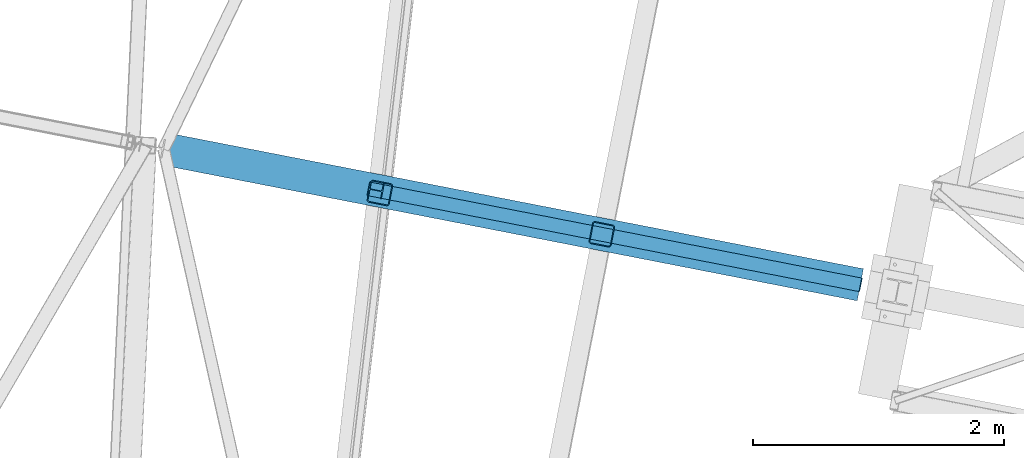
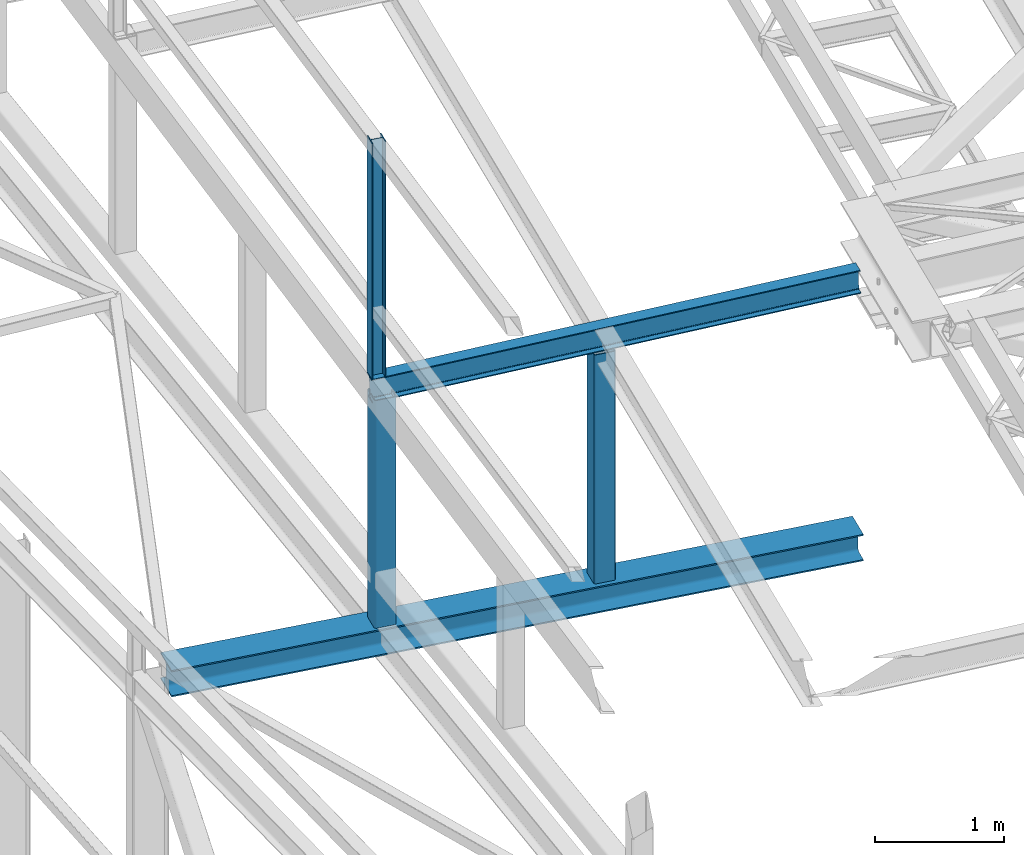
# One storey, part 65 of 215: 5 beams, 5 elements without a shape of their own.
"""IFC2X3 building model written with IfcOpenShell, lengths in millimetres."""

from ifc_helpers import new_model, si_unit, frame, origin_with_axes, origin_2d_with_axis, place, context, subcontext, project, spatial, hollow_rectangle, i_section, extrude, material, type_object, element, aggregate, save


model = new_model("IFC2X3")

# Units and contexts
model_context = context("Model", 3, precision=1e-05, world=origin_with_axes())
body_context = subcontext(model_context, "Body", "Model", "MODEL_VIEW")
ifc_project = project(units=[si_unit("LENGTHUNIT", "METRE", prefix="MILLI"), si_unit("AREAUNIT", "SQUARE_METRE"), si_unit("VOLUMEUNIT", "CUBIC_METRE"), si_unit("MASSUNIT", "GRAM", prefix="KILO"), si_unit("TIMEUNIT", "SECOND"), si_unit("PLANEANGLEUNIT", "RADIAN"), si_unit("SOLIDANGLEUNIT", "STERADIAN"), si_unit("THERMODYNAMICTEMPERATUREUNIT", "DEGREE_CELSIUS"), si_unit("LUMINOUSINTENSITYUNIT", "LUMEN")], contexts=[model_context])

# Site, building, storey
site_placement = place(None, origin_with_axes())
site = spatial("IfcSite", under=ifc_project, at=site_placement, CompositionType="ELEMENT")
building_placement = place(site_placement, origin_with_axes())
building = spatial("IfcBuilding", under=site, at=building_placement, Name="Undefined", CompositionType="ELEMENT")
storey_placement = place(building_placement, origin_with_axes())
storey = spatial("IfcBuildingStorey", under=building, at=storey_placement, Name="Undefined", CompositionType="ELEMENT", Elevation=0.0)

# Assembly, beam
assembly_1_placement = place(storey_placement, origin_with_axes())
assembly_1 = element("IfcElementAssembly", 1, at=assembly_1_placement, inside=storey, Name="Steel Assembly", AssemblyPlace="NOTDEFINED", PredefinedType="RIGID_FRAME")
ifc_material = material(Name="STEEL/S275JR")
beam_type_1 = type_object("IfcBeamType", PredefinedType="NOTDEFINED")
beam_1_placement = place(assembly_1_placement, frame((40051.0547776439, 33783.6509841996, 11827.3037944162), z_axis=(-0.981422412140383, 0.191859451027444, 0.0), x_axis=(0.0, 0.0, -1.0)))
beam_1 = element("IfcBeam", 2, at=beam_1_placement, type_object=beam_type_1, material=ifc_material, Name="MONTANT", context=body_context, shape_type="SweptSolid", body=[
    extrude(hollow_rectangle(XDim=180.0, YDim=180.0, WallThickness=8.0, InnerFilletRadius=12.0, OuterFilletRadius=20.0, at=origin_2d_with_axis()), frame((2147.50837496871, -7.27595761418343e-12, 0.0), z_axis=(-1.0, 0.0, 0.0), x_axis=(-6.93889390390723e-18, -1.0, -3.46944695195361e-18)), (0.0, 0.0, 1.0), 2147.5),
])
aggregate(assembly_1, [beam_1])

assembly_2_placement = place(storey_placement, origin_with_axes())
assembly_2 = element("IfcElementAssembly", 3, at=assembly_2_placement, inside=storey, Name="Steel Assembly", AssemblyPlace="NOTDEFINED", PredefinedType="RIGID_FRAME")
beam_2_placement = place(assembly_2_placement, frame((41817.728034466, 33454.5052548895, 11838.6109850792), z_axis=(-0.981422411901864, 0.191859450980812, -2.20469999981797e-05), x_axis=(2.16379999958709e-05, -4.22499999861833e-06, -0.999999999756973)))
beam_2 = element("IfcBeam", 4, at=beam_2_placement, type_object=beam_type_1, material=ifc_material, Name="MONTANT", context=body_context, shape_type="SweptSolid", body=[
    extrude(hollow_rectangle(XDim=180.0, YDim=180.0, WallThickness=8.0, InnerFilletRadius=12.0, OuterFilletRadius=20.0, at=origin_2d_with_axis()), frame((2171.51556602573, -7.27595545870073e-12, 7.35738091959745e-18), z_axis=(-1.0, 0.0, 0.0), x_axis=(-6.93889390390723e-18, -1.0, -3.46944695195361e-18)), (0.0, 0.0, 1.0), 2171.5),
])
aggregate(assembly_2, [beam_2])

assembly_3_placement = place(storey_placement, origin_with_axes())
assembly_3 = element("IfcElementAssembly", 5, at=assembly_3_placement, inside=storey, Name="Steel Assembly", AssemblyPlace="NOTDEFINED", PredefinedType="RIGID_FRAME")
beam_type_2 = type_object("IfcBeamType", Name="HEA120", PredefinedType="NOTDEFINED")
beam_3_placement = place(assembly_3_placement, frame((40018.1517515277, 33805.7930758167, 14219.996993795), z_axis=(0.981422409205525, -0.19185946604018, 1.89999991602007e-08), x_axis=(0.0, 0.0, -1.0)))
beam_3 = element("IfcBeam", 6, at=beam_3_placement, type_object=beam_type_2, material=ifc_material, ObjectType="HEA120", context=body_context, shape_type="SweptSolid", body=[
    extrude(i_section(OverallWidth=120.0, OverallDepth=114.0, WebThickness=5.0, FlangeThickness=8.0, FilletRadius=12.0, at=origin_2d_with_axis()), frame((2224.40782352972, 0.0, -7.35994810414025e-21), z_axis=(-1.0, 0.0, 0.0), x_axis=(-6.93889390390723e-18, -1.0, -3.46944695195361e-18)), (0.0, 0.0, 1.0), 2224.4),
])
aggregate(assembly_3, [beam_3])

assembly_4_placement = place(storey_placement, origin_with_axes())
assembly_4 = element("IfcElementAssembly", 7, at=assembly_4_placement, inside=storey, Name="Steel Assembly", AssemblyPlace="NOTDEFINED", PredefinedType="RIGID_FRAME")
beam_type_3 = type_object("IfcBeamType", Name="IPE220", PredefinedType="NOTDEFINED")
beam_4_placement = place(assembly_4_placement, frame((39961.2380791417, 33816.9769802458, 11885.6421296617), z_axis=(-0.0304453290071313, 0.00594339000139212, 0.999518763234057), x_axis=(0.980998405572889, -0.191519937111844, 0.0310200250181153)))
beam_4 = element("IfcBeam", 8, at=beam_4_placement, type_object=beam_type_3, material=ifc_material, Name="POUTRE", ObjectType="IPE220", context=body_context, shape_type="SweptSolid", body=[
    extrude(i_section(OverallWidth=110.0, OverallDepth=220.0, WebThickness=5.900000095, FlangeThickness=9.199999809, FilletRadius=12.0, at=origin_2d_with_axis()), frame((3993.11911557457, 7.43287093556035e-12, 1.80513548860154e-12), z_axis=(-1.0, 0.0, 0.0), x_axis=(-6.93889390390723e-18, -1.0, -3.46944695195361e-18)), (0.0, 0.0, 1.0), 3993.1),
])
aggregate(assembly_4, [beam_4])

assembly_5_placement = place(storey_placement, origin_with_axes())
assembly_5 = element("IfcElementAssembly", 9, at=assembly_5_placement, inside=storey, Name="Steel Assembly", AssemblyPlace="NOTDEFINED", PredefinedType="RIGID_FRAME")
beam_type_4 = type_object("IfcBeamType", Name="HEA260", PredefinedType="NOTDEFINED")
beam_5_placement = place(assembly_5_placement, frame((38330.0017767249, 34135.3873295191, 9554.79541958041), z_axis=(0.0, 0.0, 1.0), x_axis=(0.981472563610062, -0.191602731923877, 0.0)))
beam_5 = element("IfcBeam", 10, at=beam_5_placement, type_object=beam_type_4, material=ifc_material, Name="POUTRE", ObjectType="HEA260", context=body_context, shape_type="SweptSolid", body=[
    extrude(i_section(OverallWidth=260.0, OverallDepth=250.0, WebThickness=7.5, FlangeThickness=12.5, FilletRadius=24.0, at=origin_2d_with_axis()), frame((5649.80726348442, 0.0, -1.81898940354586e-12), z_axis=(-1.0, 0.0, 0.0), x_axis=(-6.93889390390723e-18, -1.0, -3.46944695195361e-18)), (0.0, 0.0, 1.0), 5649.8),
])
aggregate(assembly_5, [beam_5])

save(model, "model.ifc")
